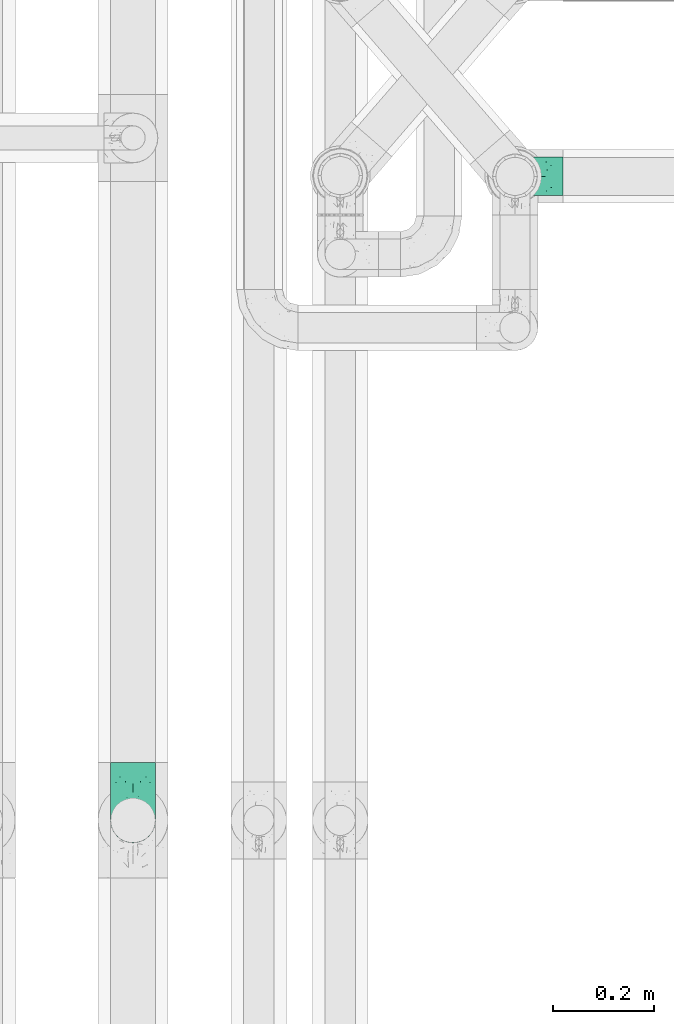
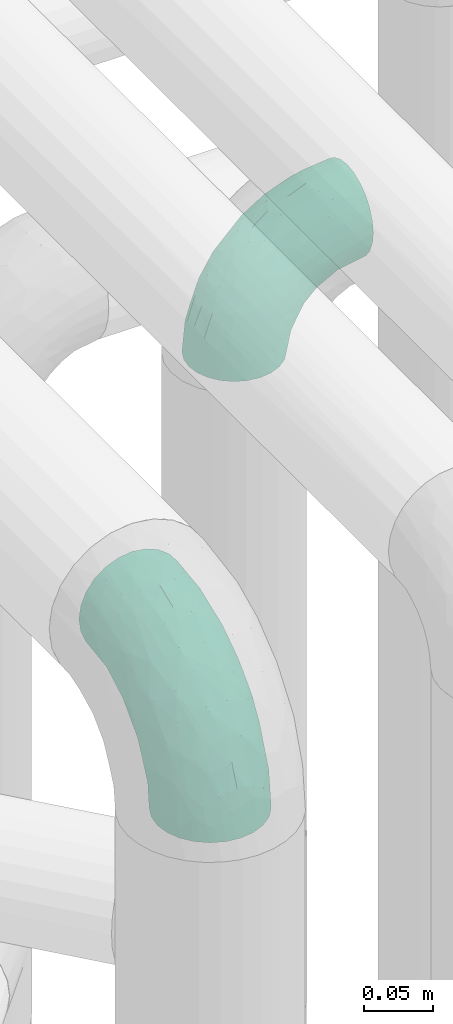
# One storey, part 797 of 827: 2 flow fittings.
"""IFC2X3 building model written with IfcOpenShell, lengths in millimetres."""

from ifc_helpers import new_model, entity, si_unit, converted_unit, derived_unit, direction, frame, origin, place, context, subcontext, project, spatial, faceted_brep, source, transform, mapped, material, type_object, type_shapes, element, save


model = new_model("IFC2X3")

# Units and contexts
model_context = context("Model", 3, precision=0.01, world=origin(), true_north=direction((6.12303176911189e-17, 1.0)))
body_context = subcontext(model_context, "Body", "Model", "MODEL_VIEW")
ifc_project = project(units=[si_unit("LENGTHUNIT", "METRE", prefix="MILLI"), si_unit("AREAUNIT", "SQUARE_METRE"), si_unit("VOLUMEUNIT", "CUBIC_METRE"), converted_unit("PLANEANGLEUNIT", "DEGREE", entity("IfcRatioMeasure", 0.0174532925199433), si_unit("PLANEANGLEUNIT", "RADIAN"), dimensions=[0, 0, 0, 0, 0, 0, 0]), si_unit("MASSUNIT", "GRAM", prefix="KILO"), derived_unit("MASSDENSITYUNIT", [(si_unit("MASSUNIT", "GRAM", prefix="KILO"), 1), (si_unit("LENGTHUNIT", "METRE"), -3)]), derived_unit("MOMENTOFINERTIAUNIT", [(si_unit("LENGTHUNIT", "METRE"), 4)]), si_unit("TIMEUNIT", "SECOND"), si_unit("FREQUENCYUNIT", "HERTZ"), si_unit("THERMODYNAMICTEMPERATUREUNIT", "DEGREE_CELSIUS"), derived_unit("THERMALTRANSMITTANCEUNIT", [(si_unit("MASSUNIT", "GRAM", prefix="KILO"), 1), (si_unit("THERMODYNAMICTEMPERATUREUNIT", "KELVIN"), -1), (si_unit("TIMEUNIT", "SECOND"), -3)]), derived_unit("VOLUMETRICFLOWRATEUNIT", [(si_unit("LENGTHUNIT", "METRE"), 3), (si_unit("TIMEUNIT", "SECOND"), -1)]), derived_unit("MASSFLOWRATEUNIT", [(si_unit("MASSUNIT", "GRAM", prefix="KILO"), 1), (si_unit("TIMEUNIT", "SECOND"), -1)]), derived_unit("ROTATIONALFREQUENCYUNIT", [(si_unit("TIMEUNIT", "SECOND"), -1)]), si_unit("ELECTRICCURRENTUNIT", "AMPERE"), si_unit("ELECTRICVOLTAGEUNIT", "VOLT"), si_unit("POWERUNIT", "WATT"), si_unit("FORCEUNIT", "NEWTON", prefix="KILO"), si_unit("ILLUMINANCEUNIT", "LUX"), si_unit("LUMINOUSFLUXUNIT", "LUMEN"), si_unit("LUMINOUSINTENSITYUNIT", "CANDELA"), derived_unit("USERDEFINED", [(si_unit("MASSUNIT", "GRAM", prefix="KILO"), -1), (si_unit("LENGTHUNIT", "METRE"), -2), (si_unit("TIMEUNIT", "SECOND"), 3), (si_unit("LUMINOUSFLUXUNIT", "LUMEN"), 1)]), derived_unit("LINEARVELOCITYUNIT", [(si_unit("LENGTHUNIT", "METRE"), 1), (si_unit("TIMEUNIT", "SECOND"), -1)]), si_unit("PRESSUREUNIT", "PASCAL"), derived_unit("USERDEFINED", [(si_unit("LENGTHUNIT", "METRE"), -2), (si_unit("MASSUNIT", "GRAM", prefix="KILO"), 1), (si_unit("TIMEUNIT", "SECOND"), -2)]), derived_unit("LINEARFORCEUNIT", [(si_unit("MASSUNIT", "GRAM", prefix="KILO"), 1), (si_unit("LENGTHUNIT", "METRE"), 1), (si_unit("TIMEUNIT", "SECOND"), -2), (si_unit("LENGTHUNIT", "METRE"), -1)]), derived_unit("PLANARFORCEUNIT", [(si_unit("MASSUNIT", "GRAM", prefix="KILO"), 1), (si_unit("LENGTHUNIT", "METRE"), 1), (si_unit("TIMEUNIT", "SECOND"), -2), (si_unit("LENGTHUNIT", "METRE"), -2)])], contexts=[model_context])

# Site, building, storey
site_placement = place(None, origin())
site = spatial("IfcSite", under=ifc_project, at=site_placement, CompositionType="ELEMENT")
building_placement = place(site_placement, origin())
building = spatial("IfcBuilding", under=site, at=building_placement, CompositionType="ELEMENT")
storey_placement = place(building_placement, frame((0.0, 0.0, 28200.0)))
storey = spatial("IfcBuildingStorey", under=building, at=storey_placement, Name="08", CompositionType="ELEMENT", Elevation=28200.0)

# Flow fittings
ifc_material = material()
pipe_fitting_type_1 = type_object("IfcPipeFittingType", Name="ADSK_1", PredefinedType="NOTDEFINED", material=ifc_material)
shared_shape_1 = source(origin(), body_context, "Body", "Brep", [
    faceted_brep([(-114.0, 22.22, -38.49), (-114.0, 11.5, -42.94), (-114.0, 0.0, -44.45), (-114.0, -11.5, -42.94), (-114.0, -22.23, -38.49), (-114.0, -31.43, -31.43), (-114.0, -38.49, -22.23), (-114.0, -42.94, -11.5), (-114.0, -44.45, 0.0), (-114.0, -42.94, 11.5), (-114.0, -38.49, 22.22), (-114.0, -31.43, 31.43), (-114.0, -22.23, 38.49), (-114.0, -11.5, 42.94), (-114.0, 0.0, 44.45), (-114.0, 11.5, 42.94), (-114.0, 22.22, 38.49), (-114.0, 31.43, 31.43), (-114.0, 38.49, 22.22), (-114.0, 42.94, 11.5), (-114.0, 44.45, 0.0), (-114.0, 42.94, -11.5), (-114.0, 38.49, -22.23), (-114.0, 31.43, -31.43), (0.0, 114.0, -44.45), (-11.5, 114.0, -42.94), (-22.23, 114.0, -38.49), (-31.43, 114.0, -31.43), (-38.49, 114.0, -22.23), (-42.94, 114.0, -11.5), (-44.45, 114.0, 0.0), (-42.94, 114.0, 11.5), (-38.49, 114.0, 22.22), (-31.43, 114.0, 31.43), (-22.23, 114.0, 38.49), (-11.5, 114.0, 42.94), (0.0, 114.0, 44.45), (11.5, 114.0, 42.94), (22.22, 114.0, 38.49), (31.43, 114.0, 31.43), (38.49, 114.0, 22.22), (42.94, 114.0, 11.5), (44.45, 114.0, 0.0), (42.94, 114.0, -11.5), (38.49, 114.0, -22.23), (31.43, 114.0, -31.43), (22.22, 114.0, -38.49), (11.5, 114.0, -42.94), (-24.5, -15.82, 8.24), (-7.18, -2.06, 7.97), (-13.53, -4.79, 15.72), (-92.03, -41.56, 0.0), (-77.08, -37.56, 14.57), (23.74, 74.96, 33.55), (-72.99, -39.05, 0.0), (-84.56, -15.6, 40.23), (-47.88, -6.37, 37.83), (-59.8, 2.77, 43.37), (-84.46, -33.54, 25.41), (16.69, 49.28, 31.02), (6.37, 47.88, 37.83), (3.35, 25.47, 29.77), (-47.43, 81.55, 19.51), (-74.96, -23.74, 33.55), (-46.77, -27.89, 11.23), (-53.88, -31.14, 0.0), (-87.05, 38.52, 28.81), (-63.44, 55.78, 24.79), (-93.24, 43.37, 18.58), (-16.67, 16.67, 37.64), (-25.47, -3.35, 29.77), (-17.2, 97.7, 41.53), (-7.42, 85.54, 44.3), (-67.09, 46.29, 31.23), (-18.08, 42.1, 44.06), (-32.93, 14.9, 42.17), (-11.54, 34.94, 41.69), (-95.7, 27.79, 36.14), (-88.55, -4.92, 43.79), (-2.77, 59.8, 43.37), (-87.65, 48.44, 9.87), (-81.01, 8.37, 44.32), (-37.63, 90.26, 28.6), (-51.29, 61.56, 30.59), (-29.32, 87.72, 36.52), (23.49, 49.5, 23.28), (8.19, 20.11, 19.18), (-70.06, 58.9, 9.01), (-87.38, 49.74, 0.0), (-88.15, 18.57, 41.8), (-7.96, 6.22, 24.33), (33.54, 84.46, 25.41), (37.56, 77.08, 14.57), (-58.37, 34.98, 40.92), (-62.38, 23.02, 43.45), (24.15, 39.93, 12.16), (31.14, 53.88, 0.0), (-58.13, 14.61, 44.45), (-37.17, 26.09, 44.37), (4.92, 88.55, 43.79), (-34.78, -23.22, 0.0), (-49.5, -23.49, 23.28), (41.56, 92.03, 0.0), (-57.83, 66.03, 19.12), (-71.84, 54.46, 17.06), (-46.46, 94.23, 8.51), (-49.74, 87.38, 0.0), (-38.96, 59.98, 38.88), (-55.29, 46.95, 36.83), (-64.82, 64.82, 0.0), (-55.88, 73.75, 10.01), (15.6, 84.56, 40.23), (-21.6, 76.38, 42.11), (-49.04, -15.53, 31.95), (-19.97, 55.59, 44.33), (-73.61, 33.95, 37.2), (-31.05, 58.14, 42.19), (-27.36, -11.22, 22.61), (-41.3, 41.3, 43.02), (9.28, 15.84, 8.73), (23.22, 34.78, 0.0), (39.05, 72.99, 0.0), (-1.96, 1.96, 0.0), (10.63, 18.37, 0.0), (-18.37, -10.63, 0.0), (-97.7, 17.2, -41.53), (9.28, 15.84, -8.73), (-13.53, -4.79, -15.72), (8.19, 20.11, -19.18), (-85.54, 7.42, -44.3), (-8.37, 81.01, -44.32), (-90.26, 37.63, -28.6), (-87.72, 29.32, -36.52), (-27.79, 95.7, -36.14), (-38.52, 87.05, -28.81), (-94.23, 46.46, -8.51), (-84.56, -15.6, -40.23), (-73.75, 55.88, -10.01), (-10.19, -4.86, -7.51), (-76.38, 21.6, -42.11), (-59.98, 38.96, -38.88), (-49.28, -16.69, -31.02), (-47.88, -6.37, -37.83), (-25.47, -3.35, -29.77), (-34.98, 58.37, -40.92), (-46.95, 55.29, -36.83), (-77.08, -37.56, -14.57), (-18.57, 88.15, -41.8), (-23.02, 62.38, -43.45), (-55.78, 63.44, -24.79), (-43.37, 93.24, -18.58), (-84.46, -33.54, -25.41), (-33.95, 73.61, -37.2), (-46.29, 67.09, -31.23), (-74.96, -23.74, -33.55), (-48.44, 87.65, -9.87), (-45.44, -27.06, -11.87), (-88.55, -4.92, -43.79), (-49.5, -23.49, -23.28), (-14.61, 58.13, -44.45), (-26.09, 37.17, -44.37), (15.6, 84.56, -40.23), (6.37, 47.88, -37.83), (-2.77, 59.8, -43.37), (-81.55, 47.43, -19.51), (33.54, 84.46, -25.41), (23.49, 49.5, -23.28), (23.74, 74.96, -33.55), (-42.1, 18.08, -44.06), (-14.9, 32.93, -42.17), (-34.94, 11.54, -41.69), (-61.56, 51.29, -30.59), (-27.36, -11.22, -22.61), (37.56, 77.08, -14.57), (4.92, 88.55, -43.79), (-59.8, 2.77, -43.37), (-66.03, 57.83, -19.12), (-54.46, 71.84, -17.06), (-55.59, 19.97, -44.33), (-58.9, 70.06, -9.01), (24.15, 39.93, -12.16), (15.53, 49.04, -31.95), (-58.14, 31.05, -42.19), (-41.3, 41.3, -43.02), (-16.67, 16.67, -37.64), (3.35, 25.47, -29.77), (-7.96, 6.22, -24.33), (-26.36, -16.33, -11.05)], [[[0, 1, 2, 3, 4, 5, 6, 7, 8, 9, 10, 11, 12, 13, 14, 15, 16, 17, 18, 19, 20, 21, 22, 23]], [[24, 25, 26, 27, 28, 29, 30, 31, 32, 33, 34, 35, 36, 37, 38, 39, 40, 41, 42, 43, 44, 45, 46, 47]], [[48, 49, 50]], [[51, 52, 9]], [[53, 39, 38]], [[9, 52, 10]], [[54, 52, 51]], [[55, 56, 57]], [[11, 10, 58]], [[59, 60, 61]], [[32, 31, 62]], [[63, 12, 11]], [[63, 55, 12]], [[64, 52, 65]], [[66, 67, 68]], [[69, 56, 70]], [[35, 71, 72]], [[67, 66, 73]], [[74, 75, 76]], [[16, 77, 17]], [[13, 78, 14]], [[76, 79, 74]], [[68, 80, 19]], [[18, 17, 66]], [[14, 78, 81]], [[20, 19, 80]], [[82, 83, 84]], [[85, 61, 86]], [[87, 88, 80]], [[18, 68, 19]], [[15, 89, 16]], [[14, 81, 15]], [[70, 90, 61]], [[17, 77, 66]], [[91, 85, 92]], [[93, 89, 94]], [[95, 96, 92]], [[84, 71, 34]], [[94, 97, 98]], [[37, 36, 99]], [[40, 39, 91]], [[40, 92, 41]], [[65, 100, 64]], [[91, 92, 40]], [[58, 101, 63]], [[92, 102, 41]], [[92, 85, 95]], [[67, 103, 104]], [[34, 33, 84]], [[105, 62, 31]], [[52, 58, 10]], [[106, 105, 30]], [[93, 107, 108]], [[106, 109, 110]], [[53, 111, 60]], [[84, 112, 71]], [[84, 107, 112]], [[33, 82, 84]], [[12, 55, 13]], [[113, 56, 63]], [[111, 38, 37]], [[34, 71, 35]], [[36, 35, 72]], [[112, 114, 72]], [[110, 105, 106]], [[111, 53, 38]], [[115, 108, 73]], [[89, 15, 81]], [[104, 87, 80]], [[110, 87, 103]], [[33, 32, 82]], [[112, 107, 116]], [[112, 116, 114]], [[99, 72, 79]], [[56, 55, 63]], [[78, 55, 57]], [[101, 117, 113]], [[56, 69, 75]], [[99, 111, 37]], [[79, 76, 60]], [[79, 60, 111]], [[60, 69, 61]], [[101, 58, 52]], [[63, 11, 58]], [[39, 53, 91]], [[85, 91, 53]], [[94, 89, 81]], [[77, 89, 115]], [[84, 83, 107]], [[93, 108, 115]], [[98, 114, 118]], [[79, 72, 114]], [[98, 118, 94]], [[98, 57, 75]], [[32, 62, 82]], [[83, 82, 62]], [[70, 113, 117]], [[61, 85, 59]], [[48, 64, 100]], [[95, 119, 120]], [[69, 70, 61]], [[70, 117, 90]], [[72, 99, 36]], [[111, 99, 79]], [[55, 78, 13]], [[81, 78, 57]], [[94, 81, 97]], [[93, 94, 118]], [[66, 68, 18]], [[80, 68, 104]], [[103, 87, 104]], [[80, 88, 20]], [[50, 49, 119]], [[95, 85, 86]], [[119, 95, 86]], [[121, 92, 96]], [[50, 119, 86]], [[119, 122, 123, 120]], [[110, 109, 87]], [[88, 87, 109]], [[62, 105, 110]], [[30, 105, 31]], [[81, 57, 97]], [[57, 98, 97]], [[107, 93, 118]], [[89, 93, 115]], [[107, 83, 108]], [[73, 108, 83]], [[67, 73, 83]], [[115, 73, 66]], [[103, 83, 62]], [[67, 104, 68]], [[83, 103, 67]], [[110, 103, 62]], [[89, 77, 16]], [[66, 77, 115]], [[56, 75, 57]], [[76, 75, 69]], [[60, 76, 69]], [[79, 114, 74]], [[114, 98, 74]], [[75, 74, 98]], [[9, 8, 51]], [[102, 92, 121]], [[102, 42, 41]], [[72, 71, 112]], [[52, 54, 65]], [[64, 48, 117]], [[101, 52, 64]], [[124, 122, 49]], [[117, 48, 50]], [[49, 48, 124]], [[119, 49, 122]], [[48, 100, 124]], [[107, 118, 116]], [[114, 116, 118]], [[101, 113, 63]], [[70, 56, 113]], [[64, 117, 101]], [[90, 50, 86]], [[50, 90, 117]], [[61, 90, 86]], [[85, 53, 59]], [[60, 59, 53]], [[95, 120, 96]], [[125, 1, 0]], [[126, 127, 128]], [[2, 1, 129]], [[24, 130, 25]], [[131, 132, 23]], [[27, 133, 134]], [[88, 135, 20]], [[136, 4, 3]], [[88, 109, 137]], [[138, 122, 124]], [[139, 132, 140]], [[141, 142, 143]], [[144, 140, 145]], [[125, 132, 139]], [[6, 146, 7]], [[144, 147, 148]], [[146, 51, 7]], [[134, 149, 150]], [[146, 6, 151]], [[152, 145, 153]], [[154, 4, 136]], [[154, 136, 142]], [[150, 155, 29]], [[43, 42, 102]], [[65, 146, 156]], [[0, 23, 132]], [[157, 3, 2]], [[146, 151, 158]], [[148, 159, 160]], [[161, 162, 163]], [[135, 164, 21]], [[165, 166, 167]], [[168, 169, 170]], [[147, 25, 130]], [[171, 132, 131]], [[155, 30, 29]], [[172, 141, 143]], [[134, 28, 27]], [[149, 134, 153]], [[173, 165, 44]], [[26, 25, 147]], [[22, 21, 164]], [[24, 174, 130]], [[133, 27, 26]], [[170, 175, 168]], [[24, 47, 174]], [[45, 167, 46]], [[28, 150, 29]], [[1, 125, 129]], [[156, 100, 65]], [[165, 45, 44]], [[161, 46, 167]], [[173, 44, 43]], [[6, 5, 151]], [[173, 102, 121]], [[137, 135, 88]], [[46, 161, 47]], [[102, 173, 43]], [[149, 176, 177]], [[172, 158, 141]], [[139, 178, 129]], [[154, 5, 4]], [[156, 146, 158]], [[106, 155, 179]], [[173, 96, 180]], [[181, 162, 167]], [[177, 179, 155]], [[137, 179, 176]], [[23, 22, 131]], [[182, 140, 183]], [[139, 182, 178]], [[157, 129, 175]], [[157, 136, 3]], [[175, 170, 142]], [[175, 142, 136]], [[142, 184, 143]], [[162, 161, 167]], [[174, 161, 163]], [[181, 166, 185]], [[162, 184, 169]], [[5, 154, 151]], [[158, 151, 154]], [[166, 165, 173]], [[167, 45, 165]], [[148, 147, 130]], [[133, 147, 152]], [[132, 171, 140]], [[144, 145, 152]], [[160, 178, 183]], [[175, 129, 178]], [[160, 183, 148]], [[160, 163, 169]], [[22, 164, 131]], [[171, 131, 164]], [[162, 185, 184]], [[186, 127, 172]], [[185, 128, 186]], [[156, 187, 100]], [[185, 166, 128]], [[143, 184, 185]], [[129, 157, 2]], [[136, 157, 175]], [[161, 174, 47]], [[130, 174, 163]], [[148, 130, 159]], [[144, 148, 183]], [[134, 150, 28]], [[155, 150, 177]], [[176, 179, 177]], [[155, 106, 30]], [[166, 180, 128]], [[128, 180, 126]], [[173, 180, 166]], [[126, 120, 123, 122]], [[120, 126, 180]], [[122, 138, 126]], [[137, 109, 179]], [[106, 179, 109]], [[164, 135, 137]], [[20, 135, 21]], [[130, 163, 159]], [[163, 160, 159]], [[140, 144, 183]], [[147, 144, 152]], [[140, 171, 145]], [[153, 145, 171]], [[149, 153, 171]], [[152, 153, 134]], [[176, 171, 164]], [[149, 177, 150]], [[171, 176, 149]], [[137, 176, 164]], [[147, 133, 26]], [[134, 133, 152]], [[162, 169, 163]], [[170, 169, 184]], [[142, 170, 184]], [[175, 178, 168]], [[178, 160, 168]], [[169, 168, 160]], [[51, 146, 54]], [[51, 8, 7]], [[132, 125, 0]], [[129, 125, 139]], [[156, 158, 172]], [[65, 54, 146]], [[178, 182, 183]], [[139, 140, 182]], [[158, 154, 141]], [[142, 141, 154]], [[186, 172, 143]], [[172, 127, 187]], [[185, 186, 143]], [[127, 186, 128]], [[187, 127, 138]], [[124, 100, 187]], [[126, 138, 127]], [[187, 138, 124]], [[172, 187, 156]], [[166, 181, 167]], [[185, 162, 181]], [[96, 173, 121]], [[96, 120, 180]]]),
])
type_shapes(pipe_fitting_type_1, [shared_shape_1])
flow_fitting_1_placement = place(storey_placement, frame((36220.03, 8807.39, 3550.0), z_axis=(1.0, 0.0, 0.0), x_axis=(0.0, -1.0, 9.29465528029239e-08)))
element("IfcFlowFitting", 1, at=flow_fitting_1_placement, inside=storey, type_object=pipe_fitting_type_1, material=ifc_material, Name="ADSK_1", ObjectType="ADSK_1", context=body_context, shape_type="MappedRepresentation", body=[
    mapped(shared_shape_1, transform((0.0, 0.0, 0.0), scale=1.0)),
])
pipe_fitting_type_2 = type_object("IfcPipeFittingType", Name="ADSK_1", PredefinedType="NOTDEFINED", material=ifc_material)
shared_shape_2 = source(origin(), body_context, "Body", "Brep", [
    faceted_brep([(-95.0, 0.0, -38.05), (-95.0, -9.85, -36.75), (-95.0, -19.03, -32.95), (-95.0, -26.91, -26.91), (-95.0, -32.95, -19.03), (-95.0, -36.75, -9.85), (-95.0, -38.05, 0.0), (-95.0, -36.75, 9.85), (-95.0, -32.95, 19.02), (-95.0, -26.91, 26.91), (-95.0, -19.03, 32.95), (-95.0, -9.85, 36.75), (-95.0, 0.0, 38.05), (-95.0, 9.85, 36.75), (-95.0, 19.02, 32.95), (-95.0, 26.91, 26.91), (-95.0, 32.95, 19.02), (-95.0, 36.75, 9.85), (-95.0, 38.05, 0.0), (-95.0, 36.75, -9.85), (-95.0, 32.95, -19.03), (-95.0, 26.91, -26.91), (-95.0, 19.02, -32.95), (-95.0, 9.85, -36.75), (-9.85, 95.0, -36.75), (-19.02, 95.0, -32.95), (-26.9, 95.0, -26.91), (-32.95, 95.0, -19.03), (-36.75, 95.0, -9.85), (-38.05, 95.0, 0.0), (-36.75, 95.0, 9.85), (-32.95, 95.0, 19.02), (-26.9, 95.0, 26.91), (-19.02, 95.0, 32.95), (-9.85, 95.0, 36.75), (0.0, 95.0, 38.05), (9.85, 95.0, 36.75), (19.03, 95.0, 32.95), (26.91, 95.0, 26.91), (32.95, 95.0, 19.02), (36.75, 95.0, 9.85), (38.05, 95.0, 0.0), (36.75, 95.0, -9.85), (32.95, 95.0, -19.03), (26.91, 95.0, -26.91), (19.03, 95.0, -32.95), (9.85, 95.0, -36.75), (0.0, 95.0, -38.05), (-7.99, -4.96, 6.3), (-0.92, 0.92, 0.0), (4.62, 8.1, 8.01), (-76.19, -35.57, 0.0), (-64.32, -32.32, 12.43), (20.51, 62.45, 28.68), (-60.56, -33.52, 0.0), (-70.4, -13.47, 34.42), (-39.61, -5.88, 32.32), (-49.6, 2.07, 37.1), (-70.34, -28.81, 21.71), (14.64, 40.81, 26.5), (5.88, 39.61, 32.32), (3.59, 20.77, 25.31), (-40.45, 68.06, 16.75), (-62.45, -20.51, 28.68), (-44.52, -26.87, 0.0), (-28.47, -20.22, 0.0), (-26.43, -17.83, 8.75), (-76.1, 39.63, 10.76), (-72.74, 37.58, 18.19), (-60.35, 46.18, 14.61), (-13.4, 13.4, 32.12), (-20.77, -3.59, 25.31), (-14.66, 81.47, 35.56), (-6.22, 71.26, 37.92), (-57.5, 42.48, 22.79), (-15.0, 34.74, 37.7), (-27.1, 12.08, 36.05), (-9.2, 28.81, 35.63), (-79.98, 23.7, 30.95), (-73.68, -4.3, 37.48), (-30.74, 21.67, 37.97), (-62.36, 47.59, 6.79), (-72.71, 32.83, 24.69), (-67.42, 7.02, 37.95), (-32.12, 75.27, 24.51), (-43.46, 51.47, 26.26), (-24.98, 73.15, 31.29), (20.59, 41.28, 19.85), (7.79, 16.09, 15.86), (-73.21, 42.39, 0.0), (-54.73, 54.73, 0.0), (-73.44, 15.79, 35.79), (-5.94, 4.32, 20.43), (28.81, 70.34, 21.71), (32.32, 64.32, 12.43), (-53.59, 26.2, 35.09), (-52.02, 19.31, 37.21), (21.38, 33.53, 10.34), (26.87, 44.52, 0.0), (-48.28, 12.14, 38.05), (4.3, 73.68, 37.48), (-44.08, -25.52, 12.79), (-41.28, -20.59, 19.85), (35.57, 76.19, 0.0), (-47.26, 54.3, 20.18), (-47.4, 61.99, 8.58), (-42.38, 73.21, 0.0), (-39.67, 78.86, 7.21), (-45.69, 36.84, 33.11), (-32.83, 50.13, 33.35), (13.47, 70.4, 34.42), (-18.25, 63.73, 36.07), (-40.63, -13.75, 27.22), (-16.63, 46.37, 37.95), (-53.47, 38.79, 28.59), (-26.07, 48.54, 36.15), (-34.51, 34.51, 36.86), (-2.07, 49.6, 37.1), (-22.79, -10.49, 19.23), (-61.73, 28.67, 31.87), (9.65, 14.7, 0.0), (20.22, 28.47, 0.0), (33.52, 60.56, 0.0), (-11.42, -5.44, 13.25), (-14.7, -9.65, 0.0), (-81.47, 14.66, -35.56), (-62.45, -20.51, -28.68), (-71.26, 6.22, -37.92), (-75.27, 32.13, -24.51), (-73.15, 24.98, -31.29), (13.47, 70.4, -34.42), (5.88, 39.61, -32.32), (-2.07, 49.6, -37.1), (-78.86, 39.67, -7.21), (-70.4, -13.47, -34.42), (-39.61, -5.88, -32.32), (-61.99, 47.4, -8.58), (32.32, 64.32, -12.43), (28.81, 70.34, -21.71), (-63.73, 18.25, -36.07), (-50.13, 32.83, -33.35), (4.3, 73.68, -37.48), (-7.01, 67.42, -37.95), (-39.63, 76.1, -10.76), (-46.18, 60.35, -14.61), (-47.59, 62.36, -6.79), (-64.32, -32.32, -12.43), (-26.2, 53.59, -35.09), (-15.79, 73.44, -35.79), (-19.31, 52.02, -37.21), (-37.58, 72.74, -18.19), (-70.34, -28.81, -21.71), (-42.48, 57.5, -22.79), (-38.79, 53.47, -28.59), (-51.47, 43.46, -26.26), (-32.82, 72.71, -24.69), (-46.37, 16.63, -37.95), (-73.68, -4.3, -37.48), (-41.28, -20.59, -19.85), (-44.08, -25.52, -12.79), (13.75, 40.63, -27.22), (20.51, 62.45, -28.68), (-68.06, 40.45, -16.75), (-54.3, 47.26, -20.18), (-12.14, 48.28, -38.05), (-21.67, 30.74, -37.97), (-36.84, 45.69, -33.11), (-11.42, -5.44, -13.25), (7.79, 16.09, -15.86), (4.62, 8.1, -8.01), (-23.7, 79.98, -30.95), (-26.43, -17.83, -8.75), (-7.99, -4.96, -6.3), (-40.81, -14.64, -26.5), (-20.77, -3.59, -25.31), (-34.74, 15.0, -37.7), (-12.08, 27.1, -36.05), (-28.81, 9.2, -35.63), (-22.79, -10.49, -19.23), (21.38, 33.53, -10.34), (20.59, 41.28, -19.85), (-48.54, 26.07, -36.15), (-49.6, 2.07, -37.1), (-13.4, 13.4, -32.12), (3.59, 20.77, -25.31), (-28.67, 61.73, -31.87), (-34.51, 34.51, -36.86), (-5.94, 4.32, -20.43)], [[[0, 1, 2, 3, 4, 5, 6, 7, 8, 9, 10, 11, 12, 13, 14, 15, 16, 17, 18, 19, 20, 21, 22, 23]], [[24, 25, 26, 27, 28, 29, 30, 31, 32, 33, 34, 35, 36, 37, 38, 39, 40, 41, 42, 43, 44, 45, 46, 47]], [[48, 49, 50]], [[51, 52, 7]], [[53, 38, 37]], [[7, 52, 8]], [[54, 52, 51]], [[55, 56, 57]], [[9, 8, 58]], [[59, 60, 61]], [[31, 30, 62]], [[63, 10, 9]], [[63, 55, 10]], [[64, 65, 66]], [[67, 68, 69]], [[70, 56, 71]], [[34, 72, 73]], [[69, 68, 74]], [[75, 76, 77]], [[14, 78, 15]], [[11, 79, 12]], [[76, 75, 80]], [[67, 69, 81]], [[16, 15, 82]], [[12, 79, 83]], [[18, 17, 67]], [[84, 85, 86]], [[87, 61, 88]], [[89, 81, 90]], [[16, 82, 68]], [[13, 91, 14]], [[12, 83, 13]], [[71, 92, 61]], [[15, 78, 82]], [[93, 87, 94]], [[95, 91, 96]], [[97, 98, 94]], [[86, 72, 33]], [[96, 99, 80]], [[36, 35, 100]], [[39, 38, 93]], [[39, 94, 40]], [[64, 66, 101]], [[93, 94, 39]], [[58, 102, 63]], [[94, 103, 40]], [[94, 87, 97]], [[104, 69, 74]], [[33, 32, 86]], [[105, 69, 104]], [[52, 58, 8]], [[106, 107, 29]], [[108, 109, 85]], [[105, 106, 90]], [[53, 110, 60]], [[86, 111, 72]], [[86, 109, 111]], [[32, 84, 86]], [[10, 55, 11]], [[112, 56, 63]], [[110, 37, 36]], [[33, 72, 34]], [[35, 34, 73]], [[111, 113, 73]], [[105, 107, 106]], [[110, 53, 37]], [[74, 114, 85]], [[91, 13, 83]], [[105, 90, 81]], [[107, 62, 30]], [[32, 31, 84]], [[115, 109, 116]], [[111, 115, 113]], [[100, 73, 117]], [[56, 55, 63]], [[79, 55, 57]], [[102, 118, 112]], [[56, 70, 76]], [[100, 110, 36]], [[117, 77, 60]], [[117, 60, 110]], [[60, 70, 61]], [[58, 52, 101]], [[63, 9, 58]], [[38, 53, 93]], [[87, 93, 53]], [[96, 91, 83]], [[78, 91, 119]], [[31, 62, 84]], [[84, 62, 104]], [[86, 85, 109]], [[85, 114, 108]], [[80, 113, 116]], [[117, 73, 113]], [[80, 116, 96]], [[80, 57, 76]], [[71, 112, 118]], [[61, 87, 59]], [[62, 107, 105]], [[97, 120, 121]], [[70, 71, 61]], [[71, 118, 92]], [[73, 100, 35]], [[110, 100, 117]], [[55, 79, 11]], [[83, 79, 57]], [[96, 83, 99]], [[116, 108, 95]], [[50, 97, 88]], [[97, 87, 88]], [[50, 49, 120]], [[122, 94, 98]], [[89, 18, 67]], [[105, 81, 69]], [[89, 67, 81]], [[68, 17, 16]], [[68, 67, 17]], [[74, 68, 82]], [[114, 82, 119]], [[74, 85, 104]], [[82, 114, 74]], [[114, 119, 108]], [[95, 108, 119]], [[116, 109, 108]], [[123, 48, 50]], [[97, 50, 120]], [[123, 50, 88]], [[91, 95, 119]], [[116, 95, 96]], [[84, 104, 85]], [[104, 62, 105]], [[83, 57, 99]], [[57, 80, 99]], [[66, 48, 123]], [[66, 124, 48]], [[118, 66, 123]], [[124, 66, 65]], [[66, 118, 101]], [[54, 64, 52]], [[124, 49, 48]], [[29, 107, 30]], [[91, 78, 14]], [[82, 78, 119]], [[56, 76, 57]], [[77, 76, 70]], [[60, 77, 70]], [[77, 117, 75]], [[117, 113, 75]], [[113, 80, 75]], [[7, 6, 51]], [[103, 94, 122]], [[103, 41, 40]], [[73, 72, 111]], [[113, 115, 116]], [[111, 109, 115]], [[102, 112, 63]], [[71, 56, 112]], [[118, 102, 101]], [[92, 123, 88]], [[123, 92, 118]], [[61, 92, 88]], [[87, 53, 59]], [[60, 59, 53]], [[97, 121, 98]], [[58, 101, 102]], [[64, 101, 52]], [[125, 23, 22]], [[126, 3, 2]], [[0, 23, 127]], [[23, 125, 127]], [[128, 129, 21]], [[130, 131, 132]], [[89, 133, 18]], [[126, 134, 135]], [[136, 89, 90]], [[137, 138, 43]], [[139, 129, 140]], [[47, 141, 142]], [[143, 144, 145]], [[125, 129, 139]], [[4, 146, 5]], [[147, 148, 149]], [[146, 51, 5]], [[143, 150, 144]], [[146, 4, 151]], [[152, 153, 154]], [[126, 2, 134]], [[22, 21, 129]], [[27, 155, 150]], [[42, 41, 103]], [[54, 146, 64]], [[139, 156, 127]], [[157, 1, 0]], [[151, 158, 159]], [[160, 131, 161]], [[20, 19, 162]], [[136, 144, 163]], [[149, 164, 165]], [[47, 142, 24]], [[166, 140, 154]], [[154, 129, 128]], [[143, 29, 28]], [[167, 168, 169]], [[155, 27, 26]], [[25, 170, 26]], [[171, 167, 172]], [[25, 24, 148]], [[26, 170, 155]], [[173, 135, 174]], [[144, 150, 152]], [[175, 176, 177]], [[47, 46, 141]], [[44, 161, 45]], [[148, 24, 142]], [[176, 175, 165]], [[64, 159, 171]], [[138, 44, 43]], [[130, 45, 161]], [[137, 43, 42]], [[178, 159, 158]], [[137, 103, 122]], [[163, 144, 152]], [[136, 133, 89]], [[103, 137, 42]], [[4, 3, 151]], [[178, 158, 173]], [[134, 2, 1]], [[178, 173, 174]], [[137, 98, 179]], [[145, 90, 106]], [[138, 180, 161]], [[45, 130, 46]], [[136, 90, 145]], [[133, 162, 19]], [[21, 20, 128]], [[139, 140, 181]], [[139, 181, 156]], [[157, 127, 182]], [[157, 134, 1]], [[182, 177, 135]], [[182, 135, 134]], [[135, 183, 174]], [[131, 130, 161]], [[141, 130, 132]], [[160, 180, 184]], [[131, 183, 176]], [[3, 126, 151]], [[158, 151, 126]], [[180, 138, 137]], [[161, 44, 138]], [[149, 148, 142]], [[170, 148, 185]], [[20, 162, 128]], [[128, 162, 163]], [[129, 154, 140]], [[154, 153, 166]], [[165, 156, 186]], [[182, 127, 156]], [[165, 186, 149]], [[165, 132, 176]], [[131, 184, 183]], [[187, 167, 178]], [[184, 168, 187]], [[167, 169, 172]], [[184, 180, 168]], [[174, 183, 184]], [[127, 157, 0]], [[134, 157, 182]], [[130, 141, 46]], [[142, 141, 132]], [[149, 142, 164]], [[186, 166, 147]], [[180, 179, 168]], [[169, 179, 120]], [[137, 179, 180]], [[179, 121, 120]], [[106, 29, 143]], [[136, 145, 144]], [[106, 143, 145]], [[150, 28, 27]], [[150, 143, 28]], [[152, 150, 155]], [[153, 155, 185]], [[152, 154, 163]], [[155, 153, 152]], [[153, 185, 166]], [[147, 166, 185]], [[186, 140, 166]], [[169, 120, 49]], [[169, 49, 172]], [[179, 169, 168]], [[148, 147, 185]], [[186, 147, 149]], [[128, 163, 154]], [[163, 162, 136]], [[142, 132, 164]], [[132, 165, 164]], [[171, 124, 65]], [[124, 171, 172]], [[64, 146, 159]], [[171, 159, 178]], [[171, 65, 64]], [[172, 49, 124]], [[162, 133, 136]], [[18, 133, 19]], [[148, 170, 25]], [[155, 170, 185]], [[131, 176, 132]], [[177, 176, 183]], [[135, 177, 183]], [[177, 182, 175]], [[182, 156, 175]], [[156, 165, 175]], [[51, 146, 54]], [[51, 6, 5]], [[129, 125, 22]], [[127, 125, 139]], [[140, 186, 181]], [[156, 181, 186]], [[158, 126, 173]], [[135, 173, 126]], [[187, 178, 174]], [[171, 178, 167]], [[184, 187, 174]], [[167, 187, 168]], [[180, 160, 161]], [[184, 131, 160]], [[98, 137, 122]], [[98, 121, 179]], [[151, 159, 146]]]),
])
type_shapes(pipe_fitting_type_2, [shared_shape_2])
flow_fitting_2_placement = place(storey_placement, frame((36975.03, 10080.2, 2899.9), z_axis=(0.0, 1.0, 0.0), x_axis=(0.0, 0.0, 1.0)))
element("IfcFlowFitting", 2, at=flow_fitting_2_placement, inside=storey, type_object=pipe_fitting_type_2, material=ifc_material, Name="ADSK_1", ObjectType="ADSK_1", context=body_context, shape_type="MappedRepresentation", body=[
    mapped(shared_shape_2, transform((0.0, 0.0, 0.0), scale=1.0)),
])

save(model, "model.ifc")
